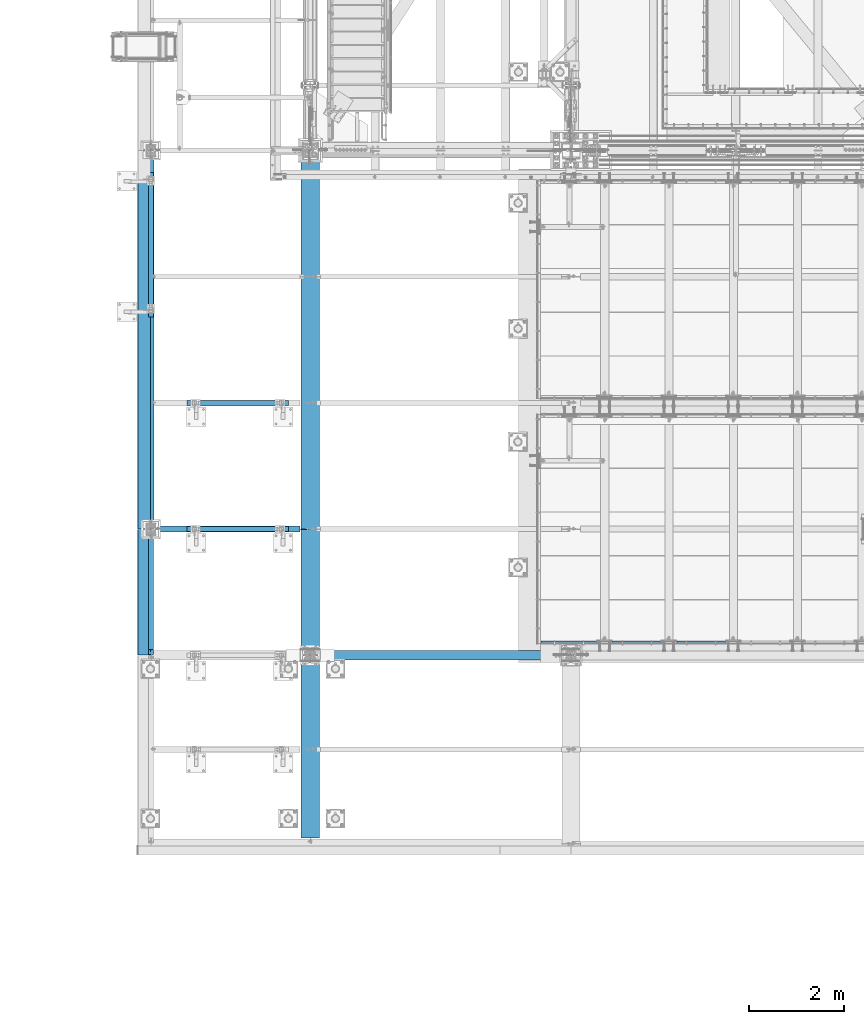
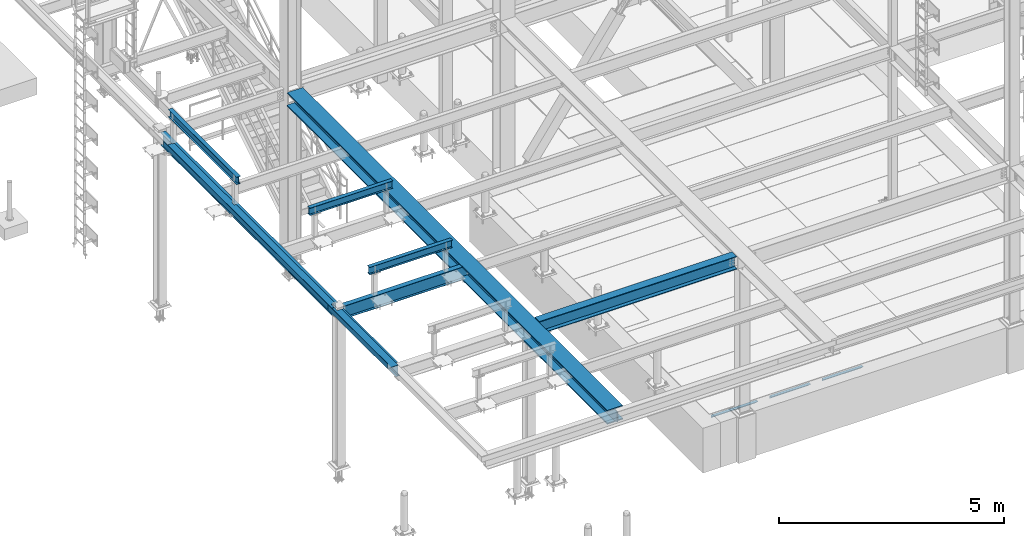
# One storey, part 1738 of 3843: 13 beams, 11 elements without a shape of their own.
"""IFC2X3 building model written with IfcOpenShell, lengths in millimetres."""

from ifc_helpers import new_model, si_unit, frame, origin_with_axes, place, context, subcontext, project, spatial, faceted_brep, material, type_object, element, aggregate, save


model = new_model("IFC2X3")

# Units and contexts
model_context = context("Model", 3, precision=1e-05, world=origin_with_axes())
body_context = subcontext(model_context, "Body", "Model", "MODEL_VIEW")
ifc_project = project(units=[si_unit("LENGTHUNIT", "METRE", prefix="MILLI"), si_unit("AREAUNIT", "SQUARE_METRE"), si_unit("VOLUMEUNIT", "CUBIC_METRE"), si_unit("MASSUNIT", "GRAM", prefix="KILO"), si_unit("TIMEUNIT", "SECOND"), si_unit("PLANEANGLEUNIT", "RADIAN"), si_unit("SOLIDANGLEUNIT", "STERADIAN"), si_unit("THERMODYNAMICTEMPERATUREUNIT", "DEGREE_CELSIUS"), si_unit("LUMINOUSINTENSITYUNIT", "LUMEN")], contexts=[model_context])

# Site, building, storey
site_placement = place(None, origin_with_axes())
site = spatial("IfcSite", under=ifc_project, at=site_placement, CompositionType="ELEMENT")
building_placement = place(site_placement, origin_with_axes())
building = spatial("IfcBuilding", under=site, at=building_placement, Name="Undefined", CompositionType="ELEMENT")
storey_placement = place(building_placement, origin_with_axes())
storey = spatial("IfcBuildingStorey", under=building, at=storey_placement, Name="Undefined", CompositionType="ELEMENT", Elevation=0.0)

# Assembly, beam
assembly_1_placement = place(storey_placement, origin_with_axes())
assembly_1 = element("IfcElementAssembly", 1, at=assembly_1_placement, inside=storey, Name="ANGLE", AssemblyPlace="NOTDEFINED", PredefinedType="RIGID_FRAME")
ifc_material_1 = material(Name="STEEL/A36")
beam_type_1 = type_object("IfcBeamType", Name="L3X3X1/4", PredefinedType="NOTDEFINED")
beam_1_placement = place(assembly_1_placement, frame((45310.4432658982, 15265.4000976563, 30365.7000030518), z_axis=(0.0, 0.0, -1.0), x_axis=(-1.0, 0.0, 0.0)))
beam_1 = element("IfcBeam", 2, at=beam_1_placement, type_object=beam_type_1, material=ifc_material_1, Name="ANGLE", ObjectType="L3X3X1/4", context=body_context, shape_type="Brep", body=[
    faceted_brep([(0.0, 38.0999999999985, -38.0999999999985), (0.0, 38.0999999999985, 38.0999999999985), (1022.33317453146, 38.1000000000004, 38.0999999999985), (1022.33317453146, 38.1000000000004, -38.0999999999985), (0.0, 31.75, 38.0999999999985), (1022.33317453146, 31.75, 38.0999999999985), (0.0, 31.75, -31.75), (1022.33317453146, 31.75, -31.75), (0.0, -38.0999999999985, -31.75), (1022.33317453146, -38.1000000000004, -31.75), (0.0, -38.0999999999985, -38.0999999999985), (1022.33317453146, -38.1000000000004, -38.0999999999985)], [[[0, 1, 2, 3]], [[1, 4, 5, 2]], [[4, 6, 7, 5]], [[6, 8, 9, 7]], [[8, 10, 11, 9]], [[10, 0, 3, 11]], [[5, 7, 9, 11, 3, 2]], [[10, 8, 6, 4, 1, 0]]]),
])
aggregate(assembly_1, [beam_1])

assembly_2_placement = place(storey_placement, origin_with_axes())
assembly_2 = element("IfcElementAssembly", 3, at=assembly_2_placement, inside=storey, Name="ANGLE", AssemblyPlace="NOTDEFINED", PredefinedType="RIGID_FRAME")
beam_2_placement = place(assembly_2_placement, frame((43957.8932658982, 15265.4000976563, 30365.7000030518), z_axis=(0.0, 0.0, -1.0), x_axis=(-1.0, 0.0, 0.0)))
beam_2 = element("IfcBeam", 4, at=beam_2_placement, type_object=beam_type_1, material=ifc_material_1, Name="ANGLE", ObjectType="L3X3X1/4", context=body_context, shape_type="Brep", body=[
    faceted_brep([(0.0, 38.0999999999985, -38.0999999999985), (0.0, 38.0999999999985, 38.0999999999985), (1022.33317453146, 38.1000000000004, 38.0999999999985), (1022.33317453146, 38.1000000000004, -38.0999999999985), (0.0, 31.75, 38.0999999999985), (1022.33317453146, 31.75, 38.0999999999985), (0.0, 31.75, -31.75), (1022.33317453146, 31.75, -31.75), (0.0, -38.0999999999985, -31.75), (1022.33317453146, -38.1000000000004, -31.75), (0.0, -38.0999999999985, -38.0999999999985), (1022.33317453146, -38.1000000000004, -38.0999999999985)], [[[0, 1, 2, 3]], [[1, 4, 5, 2]], [[4, 6, 7, 5]], [[6, 8, 9, 7]], [[8, 10, 11, 9]], [[10, 0, 3, 11]], [[5, 7, 9, 11, 3, 2]], [[10, 8, 6, 4, 1, 0]]]),
])
aggregate(assembly_2, [beam_2])

assembly_3_placement = place(storey_placement, origin_with_axes())
assembly_3 = element("IfcElementAssembly", 5, at=assembly_3_placement, inside=storey, Name="ANGLE", AssemblyPlace="NOTDEFINED", PredefinedType="RIGID_FRAME")
beam_3_placement = place(assembly_3_placement, frame((42605.3250000159, 15265.4, 30365.7000030518), z_axis=(0.0, 0.0, -1.0), x_axis=(-1.0, 0.0, 0.0)))
beam_3 = element("IfcBeam", 6, at=beam_3_placement, type_object=beam_type_1, material=ifc_material_1, Name="ANGLE", ObjectType="L3X3X1/4", context=body_context, shape_type="Brep", body=[
    faceted_brep([(0.0, 38.0999999999985, -38.0999999999985), (0.0, 38.0999999999985, 38.0999999999985), (1174.75072021487, 38.1000000000004, 38.0999999999985), (1174.75072021487, 38.1000000000004, -38.0999999999985), (0.0, 31.75, 38.0999999999985), (1174.75072021487, 31.75, 38.0999999999985), (0.0, 31.75, -31.75), (1174.75072021487, 31.75, -31.75), (0.0, -38.0999999999985, -31.75), (1174.75072021487, -38.1000000000004, -31.75), (0.0, -38.0999999999985, -38.0999999999985), (1174.75072021487, -38.1000000000004, -38.0999999999985)], [[[0, 1, 2, 3]], [[1, 4, 5, 2]], [[4, 6, 7, 5]], [[6, 8, 9, 7]], [[8, 10, 11, 9]], [[10, 0, 3, 11]], [[5, 7, 9, 11, 3, 2]], [[10, 8, 6, 4, 1, 0]]]),
])
aggregate(assembly_3, [beam_3])

assembly_4_placement = place(storey_placement, origin_with_axes())
assembly_4 = element("IfcElementAssembly", 7, at=assembly_4_placement, inside=storey, Name="BEAM", AssemblyPlace="NOTDEFINED", PredefinedType="RIGID_FRAME")
ifc_material_2 = material(Name="STEEL/A992")
beam_type_2 = type_object("IfcBeamType", Name="W12X19", PredefinedType="NOTDEFINED")
beam_4_placement = place(assembly_4_placement, frame((33223.2, 14998.7, 34656.7125), z_axis=(0.0, 0.0, 1.0), x_axis=(0.0, 1.0, 0.0)))
beam_4 = element("IfcBeam", 8, at=beam_4_placement, type_object=beam_type_2, material=ifc_material_2, Name="BEAM", ObjectType="W12X19", context=body_context, shape_type="Brep", body=[
    faceted_brep([(17.4624999999942, -3.17500000000291, -144.462500000001), (17.4624999999942, -50.8000000000029, -144.462500000001), (2516.1875, -50.8000000000029, -144.462500000001), (2516.1875, -3.17500000000291, -144.462500000001), (17.4624999999942, -50.8000000000029, -153.987500000003), (2516.1875, -50.8000000000029, -153.987500000003), (17.4624999999942, 50.8000000000029, -153.987500000003), (2516.1875, 50.8000000000029, -153.987500000003), (17.4624999999942, 50.8000000000029, -144.462500000001), (2516.1875, 50.8000000000029, -144.462500000001), (2516.1875, 3.17500000000291, -144.462500000001), (2516.1875, 3.17500000000291, 144.462500000001), (2516.1875, 50.8000000000029, 144.462500000001), (2516.1875, 50.8000000000029, 153.987500000003), (2516.1875, -50.8000000000029, 153.987500000003), (2516.1875, -50.8000000000029, 144.462500000001), (2516.1875, -3.17500000000291, 144.462500000001), (17.4624999999942, 3.17500000000291, -144.462500000001), (111.222579708789, -3.17500000000291, 123.204229922594), (111.222579708789, 3.17500000000291, 123.204229922594), (106.362500190742, 3.17500000000291, 122.237500000003), (106.362500190742, -3.17500000000291, 122.237500000003), (115.342756176942, -3.17500000000291, 125.957243823068), (115.342756176942, 3.17500000000291, 125.957243823068), (118.09577007742, -3.17500000000291, 130.077420291222), (118.09577007742, 3.17500000000291, 130.077420291222), (119.062500000007, -3.17500000000291, 134.937499809268), (119.062500000007, 3.17500000000291, 134.937499809268), (17.4624999999942, 3.17500000000291, 122.237500000003), (119.062500000007, 3.17500000000291, 144.462500000001), (119.062500000007, 50.8000000000029, 144.462500000001), (119.062500000007, 50.8000000000029, 153.987500000003), (119.062500000007, -50.8000000000029, 153.987500000003), (119.062500000007, -50.8000000000029, 144.462500000001), (119.062500000007, -3.17500000000291, 144.462500000001), (17.4624999999942, -3.17500000000291, 122.237500000003), (17.4625000000015, -3.17500000000291, 115.887499999997), (17.4625000000015, -3.17500000000291, -114.712500000001)], [[[0, 1, 2, 3]], [[1, 4, 5, 2]], [[4, 6, 7, 5]], [[6, 8, 9, 7]], [[10, 11, 12, 13, 14, 15, 16, 3, 2, 5, 7, 9]], [[8, 17, 10, 9]], [[18, 19, 20, 21]], [[22, 23, 19, 18]], [[24, 25, 23, 22]], [[26, 27, 25, 24]], [[11, 10, 17, 28, 20, 19, 23, 25, 27, 29]], [[12, 11, 29, 30]], [[13, 12, 30, 31]], [[14, 13, 31, 32]], [[15, 14, 32, 33]], [[16, 15, 33, 34]], [[32, 31, 30, 29, 27, 26, 34, 33]], [[24, 22, 18, 21, 35, 36, 37, 0, 3, 16, 34, 26]], [[17, 8, 6, 4, 1, 0, 37, 36, 35, 28]], [[21, 20, 28, 35]]]),
])

assembly_5_placement = place(storey_placement, origin_with_axes())
assembly_5 = element("IfcElementAssembly", 9, at=assembly_5_placement, inside=storey, Name="BEAM", AssemblyPlace="NOTDEFINED", PredefinedType="RIGID_FRAME")
beam_type_3 = type_object("IfcBeamType", Name="W8X13", PredefinedType="NOTDEFINED")
beam_5_placement = place(assembly_5_placement, frame((36118.8, 20307.3, 35521.8999969482), z_axis=(0.0, 0.0, 1.0), x_axis=(-1.0, 0.0, 0.0)))
beam_5 = element("IfcBeam", 10, at=beam_5_placement, type_object=beam_type_3, material=ifc_material_2, Name="BEAM", ObjectType="W8X13", context=body_context, shape_type="Brep", body=[
    faceted_brep([(0.0, 50.7999999999993, -101.599999999999), (0.0, 50.7999999999993, -95.25), (2133.6, 50.7999999999993, -95.25), (2133.6, 50.7999999999993, -101.599999999999), (0.0, 3.17499999999927, -95.25), (2133.6, 3.17499999999927, -95.25), (-2.44140610448085e-05, 3.17500000000291, 95.2499999999927), (2133.6, 3.17499999999927, 95.25), (0.0, 50.7999999999993, 95.25), (2133.6, 50.7999999999993, 95.25), (0.0, 50.7999999999993, 101.599999999999), (2133.6, 50.7999999999993, 101.599999999999), (0.0, -50.7999999999993, 101.599999999999), (2133.6, -50.7999999999993, 101.599999999999), (0.0, -50.7999999999993, 95.25), (2133.6, -50.7999999999993, 95.25), (0.0, -3.17499999999927, 95.25), (2133.6, -3.17499999999927, 95.25), (0.0, -3.17499999999927, -95.25), (2133.6, -3.17499999999927, -95.25), (0.0, -50.7999999999993, -95.25), (2133.6, -50.7999999999993, -95.25), (0.0, -50.7999999999993, -101.599999999999), (2133.6, -50.7999999999993, -101.599999999999)], [[[0, 1, 2, 3]], [[1, 4, 5, 2]], [[4, 6, 7, 5]], [[6, 8, 9, 7]], [[8, 10, 11, 9]], [[10, 12, 13, 11]], [[12, 14, 15, 13]], [[14, 16, 17, 15]], [[16, 18, 19, 17]], [[18, 20, 21, 19]], [[20, 22, 23, 21]], [[22, 0, 3, 23]], [[5, 7, 9, 11, 13, 15, 17, 19, 21, 23, 3, 2]], [[22, 20, 18, 16, 14, 12, 10, 8, 6, 4, 1, 0]]]),
])
aggregate(assembly_5, [beam_5])

assembly_6_placement = place(storey_placement, origin_with_axes())
assembly_6 = element("IfcElementAssembly", 11, at=assembly_6_placement, inside=storey, Name="BEAM", AssemblyPlace="NOTDEFINED", PredefinedType="RIGID_FRAME")
beam_6_placement = place(assembly_6_placement, frame((36118.8, 17653.0, 35521.8999969482), z_axis=(0.0, 0.0, 1.0), x_axis=(-1.0, 0.0, 0.0)))
beam_6 = element("IfcBeam", 12, at=beam_6_placement, type_object=beam_type_3, material=ifc_material_2, Name="BEAM", ObjectType="W8X13", context=body_context, shape_type="Brep", body=[
    faceted_brep([(0.0, 50.7999999999993, -101.599999999999), (0.0, 50.7999999999993, -95.25), (2133.6, 50.7999999999993, -95.25), (2133.6, 50.7999999999993, -101.599999999999), (0.0, 3.17499999999927, -95.25), (2133.6, 3.17499999999927, -95.25), (-2.44140610448085e-05, 3.17500000000291, 95.2499999999927), (2133.6, 3.17499999999927, 95.25), (0.0, 50.7999999999993, 95.25), (2133.6, 50.7999999999993, 95.25), (0.0, 50.7999999999993, 101.599999999999), (2133.6, 50.7999999999993, 101.599999999999), (0.0, -50.7999999999993, 101.599999999999), (2133.6, -50.7999999999993, 101.599999999999), (0.0, -50.7999999999993, 95.25), (2133.6, -50.7999999999993, 95.25), (0.0, -3.17499999999927, 95.25), (2133.6, -3.17499999999927, 95.25), (0.0, -3.17499999999927, -95.25), (2133.6, -3.17499999999927, -95.25), (0.0, -50.7999999999993, -95.25), (2133.6, -50.7999999999993, -95.25), (0.0, -50.7999999999993, -101.599999999999), (2133.6, -50.7999999999993, -101.599999999999)], [[[0, 1, 2, 3]], [[1, 4, 5, 2]], [[4, 6, 7, 5]], [[6, 8, 9, 7]], [[8, 10, 11, 9]], [[10, 12, 13, 11]], [[12, 14, 15, 13]], [[14, 16, 17, 15]], [[16, 18, 19, 17]], [[18, 20, 21, 19]], [[20, 22, 23, 21]], [[22, 0, 3, 23]], [[5, 7, 9, 11, 13, 15, 17, 19, 21, 23, 3, 2]], [[22, 20, 18, 16, 14, 12, 10, 8, 6, 4, 1, 0]]]),
])
aggregate(assembly_6, [beam_6])

assembly_7_placement = place(storey_placement, origin_with_axes())
assembly_7 = element("IfcElementAssembly", 13, at=assembly_7_placement, inside=storey, Name="BEAM", AssemblyPlace="NOTDEFINED", PredefinedType="RIGID_FRAME")
beam_7_placement = place(assembly_7_placement, frame((33223.2, 25158.7, 35521.8999969482), z_axis=(0.0, 0.0, 1.0), x_axis=(0.0, -1.0, 0.0)))
beam_7 = element("IfcBeam", 14, at=beam_7_placement, type_object=beam_type_3, material=ifc_material_2, Name="BEAM", ObjectType="W8X13", context=body_context, shape_type="Brep", body=[
    faceted_brep([(0.0, 50.7999999999993, -101.599999999999), (0.0, 50.7999999999993, -95.25), (3048.0, 50.8000000000029, -95.25), (3048.0, 50.8000000000029, -101.599999999999), (0.0, 3.17499999999927, -95.25), (3048.0, 3.17500000000291, -95.25), (-2.44140610448085e-05, 3.17500000000291, 95.2499999999927), (3048.0, 3.17500000000291, 95.25), (0.0, 50.7999999999993, 95.25), (3048.0, 50.8000000000029, 95.25), (0.0, 50.7999999999993, 101.599999999999), (3048.0, 50.8000000000029, 101.599999999999), (0.0, -50.7999999999993, 101.599999999999), (3048.0, -50.8000000000029, 101.599999999999), (0.0, -50.7999999999993, 95.25), (3048.0, -50.8000000000029, 95.25), (0.0, -3.17499999999927, 95.25), (3048.0, -3.17500000000291, 95.25), (0.0, -3.17499999999927, -95.25), (3048.0, -3.17500000000291, -95.25), (0.0, -50.7999999999993, -95.25), (3048.0, -50.8000000000029, -95.25), (0.0, -50.7999999999993, -101.599999999999), (3048.0, -50.8000000000029, -101.599999999999)], [[[0, 1, 2, 3]], [[1, 4, 5, 2]], [[4, 6, 7, 5]], [[6, 8, 9, 7]], [[8, 10, 11, 9]], [[10, 12, 13, 11]], [[12, 14, 15, 13]], [[14, 16, 17, 15]], [[16, 18, 19, 17]], [[18, 20, 21, 19]], [[20, 22, 23, 21]], [[22, 0, 3, 23]], [[5, 7, 9, 11, 13, 15, 17, 19, 21, 23, 3, 2]], [[22, 20, 18, 16, 14, 12, 10, 8, 6, 4, 1, 0]]]),
])
aggregate(assembly_7, [beam_7])

# Beam
beam_type_4 = type_object("IfcBeamType", PredefinedType="NOTDEFINED")
beam_8_placement = place(assembly_4_placement, frame((33223.2, 16325.652, 34813.875), z_axis=(0.0, -1.0, 0.0), x_axis=(-1.0, 0.0, 0.0)))
beam_8 = element("IfcBeam", 15, at=beam_8_placement, type_object=beam_type_4, material=ifc_material_1, Name="BENT_PLATE", context=body_context, shape_type="Brep", body=[
    faceted_brep([(114.299999999967, -3.17500000000291, -1189.23550000001), (114.299999999967, 3.17500000000291, -1189.23550000001), (114.299999999937, 3.17500000000291, -1324.1735), (114.299999999937, -3.17500000000291, -1324.1735), (0.0, -3.17500000000291, -1189.2355), (0.0, 3.17500000000291, -1189.2355), (279.399993896484, 3.17500000000291, 1324.1735), (0.0, 3.17500000000291, 1324.1735), (0.0, -3.17500000000291, 1324.1735), (273.049993896479, -3.17500000000291, 1324.1735), (273.049993896479, -136.524996948239, 1324.1735), (279.399993896484, -136.524996948239, 1324.1735), (279.399993896484, 3.17500000000291, -1324.1735), (279.399993896484, -136.524996948239, -1324.1735), (273.049993896479, -136.524996948239, -1324.1735), (273.049993896479, -3.17500000000291, -1324.1735)], [[[0, 1, 2, 3]], [[4, 5, 1, 0]], [[6, 7, 8, 9, 10, 11]], [[12, 6, 11, 13]], [[10, 14, 13, 11]], [[9, 15, 14, 10]], [[12, 13, 14, 15, 3, 2]], [[7, 6, 12, 2, 1, 5]], [[8, 7, 5, 4]], [[15, 9, 8, 4, 0, 3]]]),
])

aggregate(assembly_4, [beam_8, beam_4])

# Assembly, beams
assembly_8_placement = place(storey_placement, origin_with_axes())
assembly_8 = element("IfcElementAssembly", 16, at=assembly_8_placement, inside=storey, Name="BEAM", AssemblyPlace="NOTDEFINED", PredefinedType="RIGID_FRAME")
beam_type_5 = type_object("IfcBeamType", PredefinedType="NOTDEFINED")
beam_9_placement = place(assembly_8_placement, frame((33210.5, 21313.7745, 34813.875), z_axis=(0.0, -1.0, 0.0), x_axis=(-1.0, 0.0, 0.0)))
beam_9 = element("IfcBeam", 17, at=beam_9_placement, type_object=beam_type_5, material=ifc_material_1, Name="BENT_PLATE", context=body_context, shape_type="Brep", body=[
    faceted_brep([(44.4500000000044, -3.17500000000291, -1006.4755), (44.4500000000044, 3.17500000000291, -1006.4755), (0.0, 3.17500000000291, -1006.4755), (0.0, -3.17500000000291, -1006.4755), (44.4500000000044, -3.17500000000291, -892.175500000008), (44.4500000000044, 3.17500000000291, -892.175500000008), (0.0, -3.17500000000291, -892.175500000008), (0.0, 3.17500000000291, -892.175500000008), (101.599999999999, -3.17500000000291, 3522.662), (101.599999999999, 3.17500000000291, 3522.662), (0.0, 3.17500000000291, 3522.66200000001), (0.0, -3.17500000000291, 3522.66200000001), (101.599999999984, -3.17500000000291, 3657.60000000001), (101.599999999984, 3.17500000000291, 3657.6), (260.350012207025, -3.17500000000291, 3657.6), (260.350012207025, -136.524996948239, 3657.6), (266.700012207031, -136.524996948239, 3657.6), (266.700012207031, 3.17500000000291, 3657.6), (266.700012207031, 3.17500000000291, -3657.6), (266.700012207031, -136.524996948239, -3657.6), (260.350012207025, -136.524996948239, -3657.6), (260.350012207025, -3.17500000000291, -3657.6), (44.4500000000044, -3.17500000000291, -3657.6), (44.4500000000044, 3.17500000000291, -3657.6), (44.4500000000044, -3.17500000000291, -3635.37550000001), (44.4500000000044, 3.17500000000291, -3635.37550000001), (0.0, -3.17500000000291, -3635.37550000001), (0.0, 3.17500000000291, -3635.37550000001)], [[[0, 1, 2, 3]], [[4, 5, 1, 0]], [[6, 7, 5, 4]], [[8, 9, 10, 11]], [[12, 13, 9, 8]], [[14, 15, 16, 17, 13, 12]], [[18, 17, 16, 19]], [[15, 20, 19, 16]], [[14, 21, 20, 15]], [[18, 19, 20, 21, 22, 23]], [[24, 25, 23, 22]], [[26, 27, 25, 24]], [[27, 26, 3, 2]], [[10, 9, 13, 17, 18, 23, 25, 27, 2, 1, 5, 7]], [[11, 10, 7, 6]], [[3, 26, 24, 22, 21, 14, 12, 8, 11, 6, 4, 0]]]),
])
beam_type_6 = type_object("IfcBeamType", Name="W14X22", PredefinedType="NOTDEFINED")
beam_10_placement = place(assembly_8_placement, frame((33223.2, 17653.0, 34636.075), z_axis=(0.0, 0.0, 1.0), x_axis=(0.0, 1.0, 0.0)))
beam_10 = element("IfcBeam", 18, at=beam_10_placement, type_object=beam_type_6, material=ifc_material_2, Name="BEAM", ObjectType="W14X22", context=body_context, shape_type="Brep", body=[
    faceted_brep([(138.112499999999, -63.5, -174.625), (138.112499999999, 63.5, -174.625), (7824.78750000001, 63.5, -174.625), (7824.78750000001, -63.5, -174.625), (138.112499999999, -63.5, -166.6875), (138.112499999999, -3.17500000000291, -166.6875), (138.112499999999, -3.17500000000291, 166.6875), (138.112499999999, -63.5, 166.6875), (138.112499999999, -63.5, 174.625), (138.112499999999, 63.5, 174.625), (138.112499999999, 63.5, 166.6875), (138.112499999999, 3.17500000000291, 166.6875), (138.112499999999, 3.17500000000291, -166.6875), (138.112499999999, 63.5, -166.6875), (7824.78750000001, -63.5, -166.6875), (7824.78750000001, -3.17500000000291, -166.6875), (7824.78750000001, -3.17500000000291, 166.6875), (7824.78750000001, -63.5, 166.6875), (7824.78750000001, -63.5, 174.625), (7824.78750000001, 63.5, 174.625), (7824.78750000001, 63.5, 166.6875), (7824.78750000001, 3.17500000000291, 166.6875), (7824.78750000001, 3.17500000000291, -166.6875), (7824.78750000001, 63.5, -166.6875)], [[[0, 1, 2, 3]], [[0, 4, 5, 6, 7, 8, 9, 10, 11, 12, 13, 1]], [[5, 4, 14, 15]], [[6, 5, 15, 16]], [[7, 6, 16, 17]], [[8, 7, 17, 18]], [[9, 8, 18, 19]], [[10, 9, 19, 20]], [[11, 10, 20, 21]], [[12, 11, 21, 22]], [[13, 12, 22, 23]], [[1, 13, 23, 2]], [[22, 21, 20, 19, 18, 17, 16, 15, 14, 3, 2, 23]], [[4, 0, 3, 14]]]),
])
aggregate(assembly_8, [beam_9, beam_10])

# Assembly, beam
assembly_9_placement = place(storey_placement, origin_with_axes())
assembly_9 = element("IfcElementAssembly", 19, at=assembly_9_placement, inside=storey, Name="BEAM", AssemblyPlace="NOTDEFINED", PredefinedType="RIGID_FRAME")
beam_11_placement = place(assembly_9_placement, frame((33223.2, 17653.0, 34636.075), z_axis=(0.0, 0.0, 1.0), x_axis=(1.0, 0.0, 0.0)))
beam_11 = element("IfcBeam", 20, at=beam_11_placement, type_object=beam_type_6, material=ifc_material_2, Name="BEAM", ObjectType="W14X22", context=body_context, shape_type="Brep", body=[
    faceted_brep([(3141.66250000001, -3.17499999999927, -166.6875), (3141.66250000001, -63.5, -166.6875), (3141.66250000001, -63.5, -174.625), (3141.66250000001, 63.5, -174.625), (3141.66250000001, 63.5, -166.6875), (3141.66250000001, 3.17499999999927, -166.6875), (3141.66250000001, 3.17499999999927, -142.874999809261), (3141.66250000001, -3.17499999999927, -142.874999809261), (3142.6292299226, 3.17499999999927, -138.014920291214), (3142.6292299226, -3.17499999999927, -138.014920291214), (3145.38224382308, 3.17499999999927, -133.894743823061), (3145.38224382308, -3.17499999999927, -133.894743823061), (3149.50242029123, 3.17499999999927, -131.141729922587), (3149.50242029123, -3.17499999999927, -131.141729922587), (3154.36249980928, 3.17499999999927, -130.174999999996), (3154.36249980928, -3.17499999999927, -130.174999999996), (3330.575, -3.17499999999927, -130.174999999996), (3330.575, 3.17499999999927, -130.174999999996), (114.300000000003, 3.17499999999927, 166.6875), (114.300000000003, 63.5, 166.6875), (3141.66250000001, 63.5, 166.6875), (3141.66250000001, 3.17499999999927, 166.6875), (114.300000000003, -63.5, -174.625), (114.300000000003, -63.5, -166.6875), (114.300000000003, -3.17499999999927, -166.6875), (114.300000000003, -3.17499999999927, 166.6875), (114.300000000003, -63.5, 166.6875), (114.300000000003, -63.5, 174.625), (114.300000000003, 63.5, 174.625), (114.300000000003, 3.17499999999927, 137.264999999992), (114.300000000003, 3.17499999999927, -92.8150061035194), (114.300000000003, 3.17499999999927, -166.6875), (114.300000000003, 63.5, -166.6875), (114.300000000003, 63.5, -174.625), (3141.66250000001, -3.17499999999927, 166.6875), (3141.66250000001, -63.5, 166.6875), (3141.66250000001, -63.5, 174.625), (3141.66250000001, 63.5, 174.625), (3141.66250000001, -3.17499999999927, 142.874999809268), (3141.66250000001, 3.17499999999927, 142.874999809268), (3142.6292299226, -3.17499999999927, 138.014920291222), (3142.6292299226, 3.17499999999927, 138.014920291222), (3145.38224382308, -3.17499999999927, 133.894743823068), (3145.38224382308, 3.17499999999927, 133.894743823068), (3149.50242029123, -3.17499999999927, 131.141729922594), (3149.50242029123, 3.17499999999927, 131.141729922594), (3154.36249980928, -3.17499999999927, 130.175000000003), (3154.36249980928, 3.17499999999927, 130.175000000003), (3330.575, -3.17499999999927, 130.175000000003), (3330.575, 3.17499999999927, 130.175000000003), (3330.575, 3.17499999999927, -119.475000000006), (3330.575, 3.17499999999927, 111.125)], [[[0, 1, 2, 3, 4, 5, 6, 7]], [[7, 6, 8, 9]], [[9, 8, 10, 11]], [[11, 10, 12, 13]], [[13, 12, 14, 15]], [[16, 15, 14, 17]], [[18, 19, 20, 21]], [[22, 23, 24, 25, 26, 27, 28, 19, 18, 29, 30, 31, 32, 33]], [[26, 25, 34, 35]], [[27, 26, 35, 36]], [[28, 27, 36, 37]], [[19, 28, 37, 20]], [[36, 35, 34, 38, 39, 21, 20, 37]], [[40, 41, 39, 38]], [[42, 43, 41, 40]], [[44, 45, 43, 42]], [[46, 47, 45, 44]], [[48, 49, 47, 46]], [[50, 51, 49, 48, 16, 17]], [[12, 10, 8, 6, 5, 31, 30, 29, 18, 21, 39, 41, 43, 45, 47, 49, 51, 50, 17, 14]], [[32, 31, 5, 4]], [[33, 32, 4, 3]], [[22, 33, 3, 2]], [[23, 22, 2, 1]], [[24, 23, 1, 0]], [[48, 46, 44, 42, 40, 38, 34, 25, 24, 0, 7, 9, 11, 13, 15, 16]]]),
])
aggregate(assembly_9, [beam_11])

assembly_10_placement = place(storey_placement, origin_with_axes())
assembly_10 = element("IfcElementAssembly", 21, at=assembly_10_placement, inside=storey, Name="BEAM", AssemblyPlace="NOTDEFINED", PredefinedType="RIGID_FRAME")
beam_type_7 = type_object("IfcBeamType", Name="W14X53", PredefinedType="NOTDEFINED")
beam_12_placement = place(assembly_10_placement, frame((36576.0, 14998.7, 34634.4875), z_axis=(0.0, 0.0, 1.0), x_axis=(1.0, 0.0, 0.0)))
beam_12 = element("IfcBeam", 22, at=beam_12_placement, type_object=beam_type_7, material=ifc_material_2, Name="BEAM", ObjectType="W14X53", context=body_context, shape_type="Brep", body=[
    faceted_brep([(218.962044140164, -4.76250000000073, -158.352999496463), (218.962044140164, 4.76250000000073, -158.352999496463), (218.962044140164, 4.76250000000073, -158.75), (218.962044140164, 101.6, -158.75), (218.962044140164, 101.6, -176.212500000001), (218.962044140164, -101.6, -176.212500000001), (218.962044140164, -101.6, -158.75), (218.962044140164, -4.76250000000073, -158.75), (5287.9625, 4.76250000000073, -158.75), (5287.9625, 4.76250000000073, 158.75), (5287.9625, 101.6, 158.75), (5287.9625, 101.6, 176.212500000001), (5287.9625, -101.6, 176.212500000001), (5287.9625, -101.6, 158.75), (5287.9625, -4.76250000000073, 158.75), (5287.9625, -4.76250000000073, -158.75), (5287.9625, -101.6, -158.75), (5287.9625, -101.6, -176.212500000001), (5287.9625, 101.6, -176.212500000001), (5287.9625, 101.6, -158.75), (207.962989339387, 4.76250000000073, 158.75), (207.962989339387, 101.6, 158.75), (218.044602931928, 101.6, 176.212500000001), (218.044602931928, -101.6, 176.212500000001), (207.962989339387, -101.6, 158.75), (207.962989339387, -4.76250000000073, 158.75), (207.733789300866, 4.76250000000073, 158.352999496463), (207.733789300866, -4.76250000000073, 158.352999496463), (233.363003540042, 4.76250000000073, 158.352999496463), (233.363003540042, -4.76250000000073, 158.352999496463), (279.956447955257, 4.76250000000073, 149.040259440721), (279.956447955257, -4.76250000000073, 149.040259440721), (284.829753113903, 4.76250000000073, 146.430214982844), (284.829753113903, -4.76250000000073, 146.430214982844), (287.432595869599, 4.76250000000073, 141.553059579281), (287.432595869599, -4.76250000000073, 141.553059579281), (286.888193982551, 4.76250000000073, 136.051690492699), (286.888193982551, -4.76250000000073, 136.051690492699), (283.379932294134, 4.76250000000073, 131.779274880071), (283.379932294134, -4.76250000000073, 131.779274880071), (278.089588510353, 4.76250000000073, 130.175000000003), (278.089588510353, -4.76250000000073, 130.175000000003), (22.2249999999985, 4.76250000000073, 130.175000000003), (22.2249999999985, -4.76250000000073, 130.175000000003), (22.2249999999985, 4.76250000000073, -130.175000000003), (22.2249999999985, -4.76250000000073, -130.175000000003), (275.929589242776, 4.76250000000073, -130.175000000003), (275.929589242776, -4.76250000000073, -130.175000000003), (281.21993302655, 4.76250000000073, -131.779274880071), (281.21993302655, -4.76250000000073, -131.779274880071), (284.728194714968, 4.76250000000073, -136.051690492699), (284.728194714968, -4.76250000000073, -136.051690492699), (285.272596602015, 4.76250000000073, -141.553059579281), (285.272596602015, -4.76250000000073, -141.553059579281), (282.669753846327, 4.76250000000073, -146.430214982844), (282.669753846327, -4.76250000000073, -146.430214982844), (277.796448687674, 4.76250000000073, -149.040259440721), (277.796448687674, -4.76250000000073, -149.040259440721), (231.203004272465, 4.76250000000073, -158.352999496463), (231.203004272465, -4.76250000000073, -158.352999496463)], [[[0, 1, 2, 3, 4, 5, 6, 7]], [[8, 9, 10, 11, 12, 13, 14, 15, 16, 17, 18, 19]], [[10, 9, 20, 21]], [[11, 10, 21, 22]], [[12, 11, 22, 23]], [[13, 12, 23, 24]], [[14, 13, 24, 25]], [[23, 22, 21, 20, 26, 27, 25, 24]], [[28, 29, 27, 26]], [[29, 28, 30, 31]], [[31, 30, 32, 33]], [[33, 32, 34, 35]], [[35, 34, 36, 37]], [[37, 36, 38, 39]], [[39, 38, 40, 41]], [[41, 40, 42, 43]], [[43, 42, 44, 45]], [[46, 47, 45, 44]], [[47, 46, 48, 49]], [[49, 48, 50, 51]], [[51, 50, 52, 53]], [[53, 52, 54, 55]], [[55, 54, 56, 57]], [[57, 56, 58, 59]], [[15, 14, 25, 27, 29, 31, 33, 35, 37, 39, 41, 43, 45, 47, 49, 51, 53, 55, 57, 59, 0, 7]], [[16, 15, 7, 6]], [[17, 16, 6, 5]], [[18, 17, 5, 4]], [[19, 18, 4, 3]], [[8, 19, 3, 2]], [[58, 56, 54, 52, 50, 48, 46, 44, 42, 40, 38, 36, 34, 32, 30, 28, 26, 20, 9, 8, 2, 1]], [[59, 58, 1, 0]]]),
])
aggregate(assembly_10, [beam_12])

assembly_11_placement = place(storey_placement, origin_with_axes())
assembly_11 = element("IfcElementAssembly", 23, at=assembly_11_placement, inside=storey, Name="BEAM", AssemblyPlace="NOTDEFINED", PredefinedType="RIGID_FRAME")
beam_type_8 = type_object("IfcBeamType", Name="W14X159", PredefinedType="NOTDEFINED")
beam_13_placement = place(assembly_11_placement, frame((36576.0, 11036.3, 34620.2), z_axis=(0.0, 0.0, 1.0), x_axis=(0.0, 1.0, 0.0)))
beam_13 = element("IfcBeam", 24, at=beam_13_placement, type_object=beam_type_8, material=ifc_material_2, Name="BEAM", ObjectType="W14X159", context=body_context, shape_type="Brep", body=[
    faceted_brep([(14385.925, -198.4375, 160.337500000001), (14385.925, -9.52500000000146, 160.337500000001), (14385.925, 9.52500000000146, 160.337500000001), (14385.925, 198.4375, 160.337500000001), (14368.5104225255, 198.4375, 190.5), (14368.5104225255, -198.4375, 190.5), (119.062499999998, 198.4375, -160.337500000001), (119.062499999998, 9.52500000000146, -160.337500000001), (14382.75, 9.52500000000146, -160.337500000001), (14382.75, 198.4375, -160.337500000001), (119.062499999998, 198.4375, -190.5), (14382.75, 198.4375, -190.5), (119.062499999998, -198.4375, -190.5), (14382.75, -198.4375, -190.5), (119.062499999998, -198.4375, -160.337500000001), (14382.75, -198.4375, -160.337500000001), (119.062499999998, -9.52500000000146, -160.337500000001), (14382.75, -9.52500000000146, -160.337500000001), (119.062499999998, -9.52500000000146, -142.874999809261), (119.062499999998, 9.52500000000146, -142.874999809261), (118.095770077411, -9.52500000000146, -138.014920291214), (118.095770077411, 9.52500000000146, -138.014920291214), (115.342756176933, -9.52500000000146, -133.894743823061), (115.342756176933, 9.52500000000146, -133.894743823061), (111.222579708779, -9.52500000000146, -131.141729922587), (111.222579708779, 9.52500000000146, -131.141729922587), (106.362500190733, -9.52500000000146, -130.174999999996), (106.362500190733, 9.52500000000146, -130.174999999996), (17.4625000000015, -9.52500000000146, -130.174999999996), (17.4625000000015, 9.52500000000146, -130.174999999996), (17.4625000000015, -9.52500000000146, -90.9000000000015), (17.4625000000015, -9.52500000000146, 139.699999999997), (17.4625000000015, -9.52500000000146, 146.050000000003), (17.4625000000015, 9.52500000000146, 146.050000000003), (106.362500190733, -9.52500000000146, 146.050000000003), (106.362500190733, 9.52500000000146, 146.050000000003), (111.222579708779, -9.52500000000146, 147.016729922594), (111.222579708779, 9.52500000000146, 147.016729922594), (115.342756176933, -9.52500000000146, 149.769743823068), (115.342756176933, 9.52500000000146, 149.769743823068), (118.095770077411, -9.52500000000146, 153.889920291222), (118.095770077411, 9.52500000000146, 153.889920291222), (119.062499999998, -9.52500000000146, 158.749999809268), (119.062499999998, 9.52500000000146, 158.749999809268), (119.062499999998, -198.4375, 190.5), (119.062499999998, 198.4375, 190.5), (119.062499999998, 198.4375, 160.337500000001), (119.062499999998, 9.52500000000146, 160.337500000001), (119.062499999998, -9.52500000000146, 160.337500000001), (119.062499999998, -198.4375, 160.337500000001), (14385.925, -9.52500000000146, 159.940499999997), (14385.925, 9.52500000000146, 159.940499999997), (14346.237, -9.52500000000146, 159.940499999997), (14346.237, 9.52500000000146, 159.940499999997), (14332.8180651906, -9.52500000000146, 152.896038190993), (14332.8180651906, 9.52500000000146, 152.896038190993), (14329.1537998916, -9.52500000000146, 149.487644376204), (14329.1537998916, 9.52500000000146, 149.487644376204), (14327.7231400784, -9.52500000000146, 144.692104669659), (14327.7231400784, 9.52500000000146, 144.692104669659), (14328.9210064902, -9.52500000000146, 139.833184559415), (14328.9210064902, 9.52500000000146, 139.833184559415), (14332.4167389068, -9.52500000000146, 136.252145122373), (14332.4167389068, 9.52500000000146, 136.252145122373), (14337.2453719204, -9.52500000000146, 134.9375), (14337.2453719204, 9.52500000000146, 134.9375), (14382.75, -9.52500000000146, 134.9375), (14382.75, 9.52500000000146, 134.9375)], [[[0, 1, 2, 3, 4, 5]], [[6, 7, 8, 9]], [[10, 6, 9, 11]], [[12, 10, 11, 13]], [[14, 12, 13, 15]], [[16, 14, 15, 17]], [[18, 19, 7, 6, 10, 12, 14, 16]], [[20, 21, 19, 18]], [[22, 23, 21, 20]], [[24, 25, 23, 22]], [[26, 27, 25, 24]], [[28, 29, 27, 26]], [[30, 31, 32, 33, 29, 28]], [[34, 35, 33, 32]], [[36, 37, 35, 34]], [[38, 39, 37, 36]], [[40, 41, 39, 38]], [[42, 43, 41, 40]], [[44, 45, 46, 47, 43, 42, 48, 49]], [[44, 49, 0, 5]], [[45, 44, 5, 4]], [[46, 45, 4, 3]], [[47, 46, 3, 2]], [[50, 51, 2, 1]], [[52, 53, 51, 50]], [[54, 55, 53, 52]], [[56, 57, 55, 54]], [[58, 59, 57, 56]], [[60, 61, 59, 58]], [[62, 63, 61, 60]], [[64, 65, 63, 62]], [[65, 64, 66, 67]], [[7, 19, 21, 23, 25, 27, 29, 33, 35, 37, 39, 41, 43, 47, 2, 51, 53, 55, 57, 59, 61, 63, 65, 67, 8]], [[66, 17, 15, 13, 11, 9, 8, 67]], [[64, 62, 60, 58, 56, 54, 52, 50, 1, 48, 42, 40, 38, 36, 34, 32, 31, 30, 28, 26, 24, 22, 20, 18, 16, 17, 66]], [[49, 48, 1, 0]]]),
])
aggregate(assembly_11, [beam_13])

save(model, "model.ifc")
